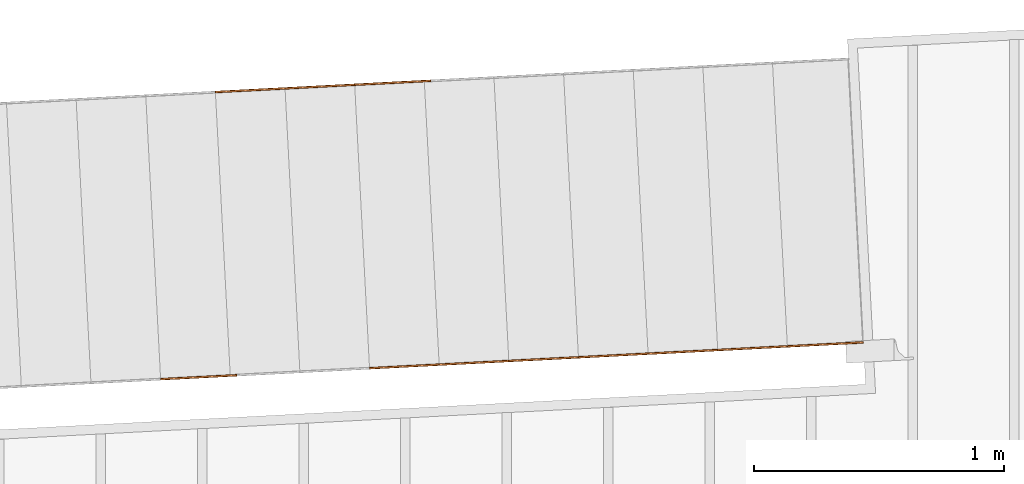
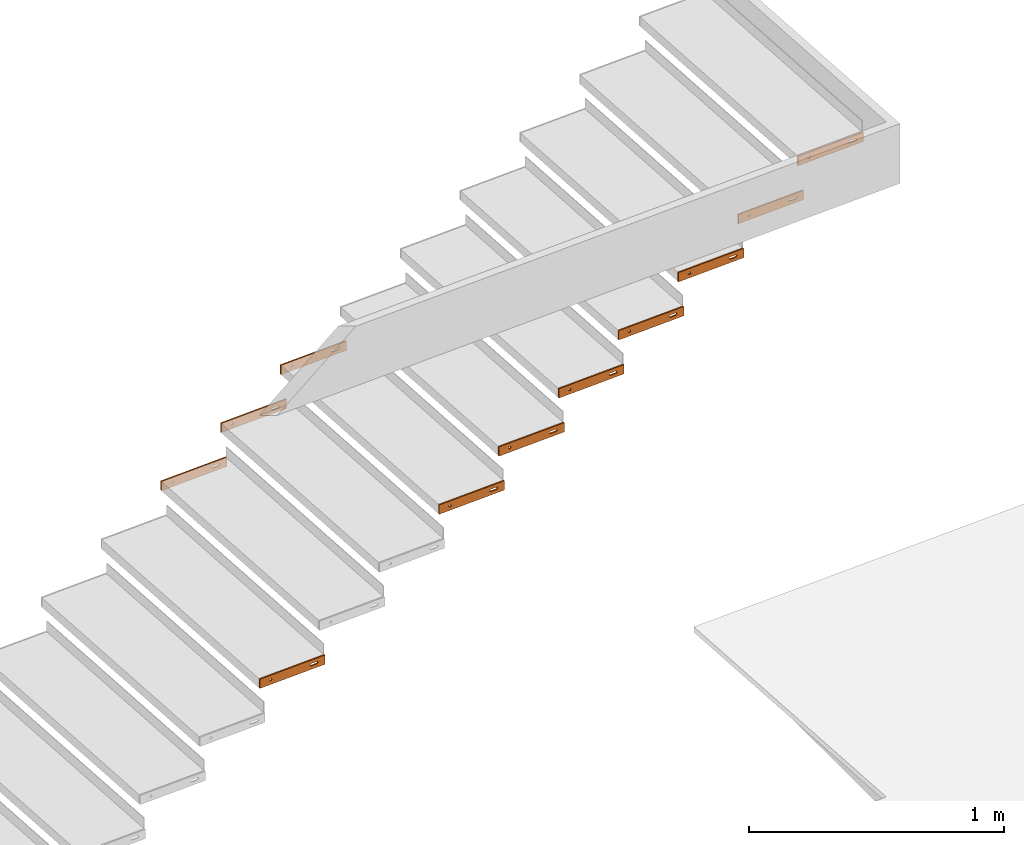
# One storey, part 18 of 23: 11 proxies.
"""IFC4 building model written with IfcOpenShell, lengths in feet."""

import ifcopenshell
import ifcopenshell.guid

model = None  # the IFC model being written
_history = None  # IfcOwnerHistory: only IFC2X3 demands one
_inside = {}  # id of a spatial element -> (the spatial element, [elements in it])
_under = {}  # id of a project, library or spatial element -> (it, [spatial elements below it])
_declared = {}  # id of a project -> (the project, [libraries it declares])
_typed = {}  # id of a type object -> (the type object, [elements of that type])
_made_of = {}  # id of a material, layer set ... -> (it, [elements and type objects made of it])


def new_model(schema):
    """Start an empty IFC model of exactly this schema.

    Asked for "IFC4X3", IfcOpenShell would pick the latest addendum, in which some entities
    have other attributes; the version numbers below select the first issue.
    IFC2X3 requires an IfcOwnerHistory on every rooted entity: one is made here for all.
    """
    global model, _history
    if schema == "IFC4X3":
        model = ifcopenshell.file(schema_version=(4, 3, 0, 0))
    else:
        model = ifcopenshell.file(schema=schema)
    _inside.clear()
    _under.clear()
    _declared.clear()
    _typed.clear()
    _made_of.clear()
    _history = None
    if model.schema == "IFC2X3":
        org = make("IfcOrganization", Name="unknown")
        user = make(
            "IfcPersonAndOrganization",
            ThePerson=make("IfcPerson", FamilyName="unknown"),
            TheOrganization=org,
        )
        app = make(
            "IfcApplication",
            ApplicationDeveloper=org,
            Version="unknown",
            ApplicationFullName="unknown",
            ApplicationIdentifier="unknown",
        )
        _history = make(
            "IfcOwnerHistory",
            OwningUser=user,
            OwningApplication=app,
            ChangeAction="ADDED",
            CreationDate=0,
        )
    return model


def make(cls, **values):
    """One entity of the class cls with the attributes given. An attribute that is None is left unset."""
    return model.create_entity(
        cls, **{name: value for name, value in values.items() if value is not None}
    )


def entity(cls, *values):
    """Any entity or typed value of the class cls, its attributes in the order of the schema. None: left unset."""
    e = model.create_entity(cls)
    for i, value in enumerate(values):
        if value is not None:
            e[i] = value
    return e


def rooted(cls, **values):
    """An entity with a GlobalId (a new one), such as an element, a storey or a relation."""
    return make(cls, GlobalId=ifcopenshell.guid.new(), OwnerHistory=_history, **values)


def si_unit(unit_type, name, prefix=None):
    """IfcSIUnit, for example si_unit("LENGTHUNIT", "METRE", prefix="MILLI")."""
    return make("IfcSIUnit", UnitType=unit_type, Prefix=prefix, Name=name)


def converted_unit(unit_type, name, factor, base, dimensions=None, offset=None):
    """IfcConversionBasedUnit, such as the inch: factor (a typed value) times the base unit."""
    return make(
        "IfcConversionBasedUnit"
        if offset is None
        else "IfcConversionBasedUnitWithOffset",
        ConversionOffset=offset,
        Dimensions=None
        if dimensions is None
        else entity("IfcDimensionalExponents", *dimensions),
        UnitType=unit_type,
        Name=name,
        ConversionFactor=make(
            "IfcMeasureWithUnit", ValueComponent=factor, UnitComponent=base
        ),
    )


def derived_unit(unit_type, elements):
    """IfcDerivedUnit: a product of units, each with its exponent."""
    return make(
        "IfcDerivedUnit",
        Elements=[
            make("IfcDerivedUnitElement", Unit=unit, Exponent=power)
            for unit, power in elements
        ],
        UnitType=unit_type,
    )


def assignment(units):
    """IfcUnitAssignment: the units of a project."""
    return None if units is None else make("IfcUnitAssignment", Units=units)


def point(xyz):
    """IfcCartesianPoint."""
    return None if xyz is None else make("IfcCartesianPoint", Coordinates=xyz)


def direction(xyz):
    """IfcDirection."""
    return None if xyz is None else make("IfcDirection", DirectionRatios=xyz)


def frame(location, z_axis=None, x_axis=None):
    """IfcAxis2Placement3D, a coordinate frame: its origin and axes. An axis left out is left unset."""
    return make(
        "IfcAxis2Placement3D",
        Location=point(location),
        Axis=direction(z_axis),
        RefDirection=direction(x_axis),
    )


def frame_2d(location, x_axis=None):
    """IfcAxis2Placement2D, a coordinate frame in the plane: its origin and x axis."""
    return make(
        "IfcAxis2Placement2D", Location=point(location), RefDirection=direction(x_axis)
    )


def origin():
    """The frame at (0, 0, 0) with its axes left unset."""
    return frame((0.0, 0.0, 0.0))


def place(relative_to, where):
    """IfcLocalPlacement: puts the frame where relative to a parent placement (None: the world)."""
    return make(
        "IfcLocalPlacement", PlacementRelTo=relative_to, RelativePlacement=where
    )


def context(
    kind, dimensions, precision=None, world=None, true_north=None, identifier=None
):
    """IfcGeometricRepresentationContext, for example the 3D "Model" context."""
    return make(
        "IfcGeometricRepresentationContext",
        ContextIdentifier=identifier,
        ContextType=kind,
        CoordinateSpaceDimension=dimensions,
        Precision=precision,
        WorldCoordinateSystem=world,
        TrueNorth=true_north,
    )


def subcontext(parent, identifier, kind, view, scale=None):
    """IfcGeometricRepresentationSubContext, for example "Body" below "Model"."""
    return make(
        "IfcGeometricRepresentationSubContext",
        ContextIdentifier=identifier,
        ContextType=kind,
        ParentContext=parent,
        TargetScale=scale,
        TargetView=view,
    )


def project(units=None, contexts=None):
    """IfcProject with its units and contexts."""
    return rooted(
        "IfcProject",
        Name="project",
        RepresentationContexts=contexts,
        UnitsInContext=assignment(units),
    )


def spatial(cls, under=None, at=None, **own):
    """A site, building, storey or space (cls), placed at a placement, below another one or the project."""
    s = rooted(cls, ObjectPlacement=at, **own)
    if under is not None:
        _under.setdefault(under.id(), (under, []))[1].append(s)
    return s


def polyline(points):
    """IfcPolyline through the points."""
    return make("IfcPolyline", Points=[point(p) for p in points])


def circle_curve(where, radius):
    """IfcCircle in the frame where."""
    return make("IfcCircle", Position=where, Radius=radius)


def parameter(value):
    """IfcParameterValue: where a trimmed curve begins or ends, as a parameter of its basis curve."""
    return model.create_entity("IfcParameterValue", value)


def trimmed(basis, trim1, trim2, sense, master):
    """IfcTrimmedCurve: the piece of a basis curve between two trims."""
    return make(
        "IfcTrimmedCurve",
        BasisCurve=basis,
        Trim1=trim1,
        Trim2=trim2,
        SenseAgreement=sense,
        MasterRepresentation=master,
    )


def segment(curve, same_sense, transition):
    """IfcCompositeCurveSegment."""
    return make(
        "IfcCompositeCurveSegment",
        Transition=transition,
        SameSense=same_sense,
        ParentCurve=curve,
    )


def composite_curve(segments, self_intersect=None):
    """IfcCompositeCurve: segments joined end to end."""
    return make("IfcCompositeCurve", Segments=segments, SelfIntersect=self_intersect)


def outline(outer, holes=None, kind="AREA"):
    """IfcArbitraryClosedProfileDef: a profile drawn as a closed curve; with holes, ...WithVoids."""
    if holes is None:
        return make("IfcArbitraryClosedProfileDef", ProfileType=kind, OuterCurve=outer)
    return make(
        "IfcArbitraryProfileDefWithVoids",
        ProfileType=kind,
        OuterCurve=outer,
        InnerCurves=holes,
    )


def extrude(swept, where, along, depth):
    """IfcExtrudedAreaSolid: the profile swept, set in the frame where, extruded along a direction by depth."""
    return make(
        "IfcExtrudedAreaSolid",
        SweptArea=swept,
        Position=where,
        ExtrudedDirection=direction(along),
        Depth=depth,
    )


def shape(context_of_items, identifier, shape_type, items):
    """IfcShapeRepresentation: the items that make up one representation, for example the "Body"."""
    return make(
        "IfcShapeRepresentation",
        ContextOfItems=context_of_items,
        RepresentationIdentifier=identifier,
        RepresentationType=shape_type,
        Items=items,
    )


def source(mapping_origin, context_of_items, identifier, shape_type, items):
    """IfcRepresentationMap: a shape defined once, which mapped items show again and again."""
    return make(
        "IfcRepresentationMap",
        MappingOrigin=mapping_origin,
        MappedRepresentation=shape(context_of_items, identifier, shape_type, items),
    )


def transform(
    local_origin,
    x_axis=None,
    y_axis=None,
    z_axis=None,
    scale=None,
    scale2=None,
    scale3=None,
    uniform=True,
):
    """IfcCartesianTransformationOperator3D, or its non-uniform kind. x_axis, y_axis, z_axis: its Axis1, 2, 3."""
    if uniform:
        return make(
            "IfcCartesianTransformationOperator3D",
            Axis1=direction(x_axis),
            Axis2=direction(y_axis),
            LocalOrigin=point(local_origin),
            Scale=scale,
            Axis3=direction(z_axis),
        )
    return make(
        "IfcCartesianTransformationOperator3DnonUniform",
        Axis1=direction(x_axis),
        Axis2=direction(y_axis),
        LocalOrigin=point(local_origin),
        Scale=scale,
        Axis3=direction(z_axis),
        Scale2=scale2,
        Scale3=scale3,
    )


def mapped(mapping_source, mapping_target):
    """IfcMappedItem: shows the shape of a source again, moved by a transform."""
    return make(
        "IfcMappedItem", MappingSource=mapping_source, MappingTarget=mapping_target
    )


def material(Name=None, Category=None):
    """IfcMaterial."""
    return make("IfcMaterial", Name=Name, Category=Category)


def made_of(thing, what):
    """Note that an element or type object is made of a material, layer set ...; save() writes the relation."""
    if what is not None:
        _made_of.setdefault(what.id(), (what, []))[1].append(thing)
    return thing


def type_object(cls, material=None, **own):
    """A type object (cls), such as IfcWallType, which elements share."""
    return made_of(rooted(cls, **own), material)


def type_shapes(of_type, sources):
    """Give a type object the sources (RepresentationMaps) that its elements show as mapped items."""
    of_type.RepresentationMaps = sources


def element(
    cls,
    number,
    at=None,
    inside=None,
    cuts=None,
    type_object=None,
    material=None,
    context=None,
    identifier="Body",
    shape_type=None,
    held_by="IfcProductDefinitionShape",
    body=None,
    shapes=None,
    **own,
):
    """One element of the class cls, such as IfcWall. Its Tag is "e" and its number.

    at: its placement. inside: the storey or other place that contains it. cuts: it is an
    opening in that element (IfcRelVoidsElement). A single representation is given by context,
    identifier, shape_type and body (its items); several are given by shapes. held_by: the class
    of the entity that holds the representations. save() writes the other relations.
    """
    e = rooted(cls, Tag="e%d" % number, ObjectPlacement=at, **own)
    if body is not None:
        shapes = [shape(context, identifier, shape_type, body)]
    if shapes is not None:
        e.Representation = make(held_by, Representations=shapes)
    if inside is not None:
        _inside.setdefault(inside.id(), (inside, []))[1].append(e)
    if cuts is not None:
        rooted(
            "IfcRelVoidsElement", RelatingBuildingElement=cuts, RelatedOpeningElement=e
        )
    if type_object is not None:
        _typed.setdefault(type_object.id(), (type_object, []))[1].append(e)
    return made_of(e, material)


def aggregate(whole, parts):
    """IfcRelAggregates: a whole, such as a stair, and the parts it consists of."""
    return rooted("IfcRelAggregates", RelatingObject=whole, RelatedObjects=parts)


def save(model, path):
    """Write the relations noted so far, then the file.

    IfcRelAggregates (storeys below a building ...), IfcRelContainedInSpatialStructure (elements
    in a storey), IfcRelDefinesByType, IfcRelAssociatesMaterial and IfcRelDeclares: one each for
    every whole, place, type object, material and project.
    """
    for whole, parts in _under.values():
        aggregate(whole, parts)
    for where, things in _inside.values():
        rooted(
            "IfcRelContainedInSpatialStructure",
            RelatedElements=things,
            RelatingStructure=where,
        )
    for kind, things in _typed.values():
        rooted("IfcRelDefinesByType", RelatedObjects=things, RelatingType=kind)
    for what, things in _made_of.values():
        rooted("IfcRelAssociatesMaterial", RelatedObjects=things, RelatingMaterial=what)
    for by, libraries in _declared.values():
        rooted("IfcRelDeclares", RelatingContext=by, RelatedDefinitions=libraries)
    model.write(path)


model = new_model("IFC4")

# Units and contexts
model_context_1 = context("Model", 3, precision=0.0001, world=origin(), true_north=direction((6.12303176911189e-17, 1.0)))
model_context_2 = context("Model", 3, precision=0.0001, world=origin(), true_north=direction((6.12303176911189e-17, 1.0)))
body_context = subcontext(model_context_2, "Body", "Model", "MODEL_VIEW")
ifc_project = project(units=[converted_unit("LENGTHUNIT", "FOOT", entity("IfcRatioMeasure", 0.3048), si_unit("LENGTHUNIT", "METRE"), dimensions=[1, 0, 0, 0, 0, 0, 0]), converted_unit("AREAUNIT", "SQUARE FOOT", entity("IfcRatioMeasure", 0.09290304), si_unit("AREAUNIT", "SQUARE_METRE"), dimensions=[2, 0, 0, 0, 0, 0, 0]), converted_unit("VOLUMEUNIT", "CUBIC FOOT", entity("IfcRatioMeasure", 0.028316846592), si_unit("VOLUMEUNIT", "CUBIC_METRE"), dimensions=[3, 0, 0, 0, 0, 0, 0]), converted_unit("PLANEANGLEUNIT", "DEGREE", entity("IfcRatioMeasure", 0.0174532925199433), si_unit("PLANEANGLEUNIT", "RADIAN"), dimensions=[0, 0, 0, 0, 0, 0, 0]), si_unit("MASSUNIT", "GRAM", prefix="KILO"), derived_unit("MASSDENSITYUNIT", [(si_unit("MASSUNIT", "GRAM", prefix="KILO"), 1), (si_unit("LENGTHUNIT", "METRE"), -3)]), derived_unit("MOMENTOFINERTIAUNIT", [(si_unit("LENGTHUNIT", "METRE"), 4)]), si_unit("TIMEUNIT", "SECOND"), si_unit("FREQUENCYUNIT", "HERTZ"), si_unit("THERMODYNAMICTEMPERATUREUNIT", "DEGREE_CELSIUS"), derived_unit("THERMALTRANSMITTANCEUNIT", [(si_unit("MASSUNIT", "GRAM", prefix="KILO"), 1), (si_unit("THERMODYNAMICTEMPERATUREUNIT", "KELVIN"), -1), (si_unit("TIMEUNIT", "SECOND"), -3)]), derived_unit("VOLUMETRICFLOWRATEUNIT", [(si_unit("LENGTHUNIT", "METRE"), 3), (si_unit("TIMEUNIT", "SECOND"), -1)]), si_unit("ELECTRICCURRENTUNIT", "AMPERE"), si_unit("ELECTRICVOLTAGEUNIT", "VOLT"), si_unit("POWERUNIT", "WATT"), si_unit("FORCEUNIT", "NEWTON"), si_unit("ILLUMINANCEUNIT", "LUX"), si_unit("LUMINOUSFLUXUNIT", "LUMEN"), si_unit("LUMINOUSINTENSITYUNIT", "CANDELA"), derived_unit("USERDEFINED", [(si_unit("MASSUNIT", "GRAM", prefix="KILO"), -1), (si_unit("LENGTHUNIT", "METRE"), -2), (si_unit("TIMEUNIT", "SECOND"), 3), (si_unit("LUMINOUSFLUXUNIT", "LUMEN"), 1)]), derived_unit("LINEARVELOCITYUNIT", [(si_unit("LENGTHUNIT", "METRE"), 1), (si_unit("TIMEUNIT", "SECOND"), -1)]), si_unit("PRESSUREUNIT", "PASCAL"), derived_unit("USERDEFINED", [(si_unit("LENGTHUNIT", "METRE"), -2), (si_unit("MASSUNIT", "GRAM", prefix="KILO"), 1), (si_unit("TIMEUNIT", "SECOND"), -2)]), derived_unit("LINEARFORCEUNIT", [(si_unit("MASSUNIT", "GRAM", prefix="KILO"), 1), (si_unit("LENGTHUNIT", "METRE"), 1), (si_unit("TIMEUNIT", "SECOND"), -2), (si_unit("LENGTHUNIT", "METRE"), -1)]), derived_unit("PLANARFORCEUNIT", [(si_unit("MASSUNIT", "GRAM", prefix="KILO"), 1), (si_unit("LENGTHUNIT", "METRE"), 1), (si_unit("TIMEUNIT", "SECOND"), -2), (si_unit("LENGTHUNIT", "METRE"), -2)])], contexts=[model_context_1])

# Site, building, storey
site_placement = place(None, origin())
site = spatial("IfcSite", under=ifc_project, at=site_placement, CompositionType="ELEMENT")
building_placement = place(site_placement, origin())
building = spatial("IfcBuilding", under=site, at=building_placement, CompositionType="ELEMENT")
storey_placement = place(building_placement, frame((0.0, 0.0, 10.8020833333333)))
storey = spatial("IfcBuildingStorey", under=building, at=storey_placement, Name="2ND FLOOR", CompositionType="ELEMENT", Elevation=10.8020833333333)

# Proxies
ifc_material = material(Name="GALV. STEEL TREAD", Category="Materials")
building_element_proxy_type_1 = type_object("IfcBuildingElementProxyType", Name="Generic Models 972:Generic Models 629", PredefinedType="NOTDEFINED", material=ifc_material)
shared_shape_1 = source(origin(), body_context, "Body", "SweptSolid", [
    extrude(outline(polyline([(-0.499999999999973, -0.0729166666666679), (0.499999999999967, -0.0729166666666679), (0.500000000000001, 0.0729166666666679), (-0.499999999999967, 0.0729166666666679), (-0.499999999999973, -0.0729166666666679)]), holes=[composite_curve([segment(trimmed(circle_curve(frame_2d((-0.333333333333324, 0.0), x_axis=(-1.0, 0.0)), 0.0182291666666717), [parameter(180.0)], [parameter(360.0)], True, "PARAMETER"), False, "CONTINUOUS"), segment(trimmed(circle_curve(frame_2d((-0.33333333333333, 0.0), x_axis=(-1.0, 0.0)), 0.0182291666666717), [parameter(360.0)], [parameter(180.0)], True, "PARAMETER"), False, "CONTINUOUS")], self_intersect=False), composite_curve([segment(polyline([(0.376206281053262, -0.018229166666675), (0.290460385613239, -0.0182291666667105)]), True, "CONTINUOUS"), segment(trimmed(circle_curve(frame_2d((0.290460385613239, 0.0), x_axis=(1.0, 0.0)), 0.0182291666666714), [parameter(89.999999999957)], [parameter(269.999999999957)], True, "PARAMETER"), False, "CONTINUOUS"), segment(polyline([(0.290460385613245, 0.0182291666666679), (0.376206281053234, 0.0182291666666679)]), True, "CONTINUOUS"), segment(trimmed(circle_curve(frame_2d((0.376206281053262, 0.0), x_axis=(-1.0, 0.0)), 0.0182291666666714), [parameter(90.0000000000894)], [parameter(270.000000000089)], True, "PARAMETER"), False, "CONTINUOUS")], self_intersect=False)]), frame((0.500405099798996, 0.0261679781215207, 0.0729166666666679), z_axis=(-0.0523359562429309, 0.998629534754575, 0.0), x_axis=(0.998629534754575, 0.0523359562429309, 0.0)), (0.0, 0.0, 1.0), 0.0208333333333866),
])
type_shapes(building_element_proxy_type_1, [shared_shape_1])
proxy_1_placement = place(storey_placement, frame((-229.797734568391, 969.063958932095, 6.41392543859647)))
element("IfcBuildingElementProxy", 1, at=proxy_1_placement, inside=storey, type_object=building_element_proxy_type_1, material=ifc_material, Name="Generic Models 972:Generic Models 629", ObjectType="Generic Models 972:Generic Models 629", PredefinedType="NOTDEFINED", context=body_context, shape_type="MappedRepresentation", body=[
    mapped(shared_shape_1, transform((0.0, 0.0, 0.0), scale=1.0)),
])
building_element_proxy_type_2 = type_object("IfcBuildingElementProxyType", Name="Generic Models 973:Generic Models 629", PredefinedType="NOTDEFINED", material=ifc_material)
shared_shape_2 = source(origin(), body_context, "Body", "SweptSolid", [
    extrude(outline(polyline([(-0.499999999999973, -0.0729166666666679), (0.499999999999967, -0.0729166666666679), (0.500000000000001, 0.0729166666666679), (-0.499999999999967, 0.0729166666666679), (-0.499999999999973, -0.0729166666666679)]), holes=[composite_curve([segment(trimmed(circle_curve(frame_2d((-0.33333333333333, 0.0), x_axis=(-1.0, 0.0)), 0.0182291666666717), [parameter(180.0)], [parameter(360.0)], True, "PARAMETER"), False, "CONTINUOUS"), segment(trimmed(circle_curve(frame_2d((-0.333333333333336, 0.0), x_axis=(-1.0, 0.0)), 0.0182291666666717), [parameter(360.0)], [parameter(180.0)], True, "PARAMETER"), False, "CONTINUOUS")], self_intersect=False), composite_curve([segment(polyline([(0.376206281053256, -0.018229166666675), (0.290460385613233, -0.0182291666667105)]), True, "CONTINUOUS"), segment(trimmed(circle_curve(frame_2d((0.290460385613233, 0.0), x_axis=(1.0, 0.0)), 0.0182291666666714), [parameter(89.999999999957)], [parameter(269.999999999957)], True, "PARAMETER"), False, "CONTINUOUS"), segment(polyline([(0.290460385613239, 0.0182291666666679), (0.376206281053228, 0.0182291666666679)]), True, "CONTINUOUS"), segment(trimmed(circle_curve(frame_2d((0.376206281053256, 0.0), x_axis=(-1.0, 0.0)), 0.0182291666666714), [parameter(90.0000000000894)], [parameter(270.000000000089)], True, "PARAMETER"), False, "CONTINUOUS")], self_intersect=False)]), frame((0.500405099798996, 0.0261679781215207, 0.0729166666666679), z_axis=(-0.0523359562429309, 0.998629534754575, 0.0), x_axis=(0.998629534754575, 0.0523359562429309, 0.0)), (0.0, 0.0, 1.0), 0.0208333333333866),
])
type_shapes(building_element_proxy_type_2, [shared_shape_2])
proxy_2_placement = place(storey_placement, frame((-230.712606310766, 969.016012535749, 5.85252192982451)))
element("IfcBuildingElementProxy", 2, at=proxy_2_placement, inside=storey, type_object=building_element_proxy_type_2, material=ifc_material, Name="Generic Models 973:Generic Models 629", ObjectType="Generic Models 973:Generic Models 629", PredefinedType="NOTDEFINED", context=body_context, shape_type="MappedRepresentation", body=[
    mapped(shared_shape_2, transform((0.0, 0.0, 0.0), scale=1.0)),
])
building_element_proxy_type_3 = type_object("IfcBuildingElementProxyType", Name="Generic Models 974:Generic Models 629", PredefinedType="NOTDEFINED", material=ifc_material)
shared_shape_3 = source(origin(), body_context, "Body", "SweptSolid", [
    extrude(outline(polyline([(-0.499999999999973, -0.0729166666666679), (0.499999999999967, -0.0729166666666679), (0.500000000000001, 0.0729166666666679), (-0.499999999999967, 0.0729166666666679), (-0.499999999999973, -0.0729166666666679)]), holes=[composite_curve([segment(trimmed(circle_curve(frame_2d((-0.33333333333333, 0.0), x_axis=(-1.0, 0.0)), 0.0182291666666717), [parameter(180.0)], [parameter(360.0)], True, "PARAMETER"), False, "CONTINUOUS"), segment(trimmed(circle_curve(frame_2d((-0.333333333333336, 0.0), x_axis=(-1.0, 0.0)), 0.0182291666666717), [parameter(360.0)], [parameter(180.0)], True, "PARAMETER"), False, "CONTINUOUS")], self_intersect=False), composite_curve([segment(polyline([(0.376206281053256, -0.018229166666675), (0.290460385613233, -0.0182291666667105)]), True, "CONTINUOUS"), segment(trimmed(circle_curve(frame_2d((0.290460385613233, 0.0), x_axis=(1.0, 0.0)), 0.0182291666666714), [parameter(89.999999999957)], [parameter(269.999999999957)], True, "PARAMETER"), False, "CONTINUOUS"), segment(polyline([(0.290460385613239, 0.0182291666666679), (0.376206281053228, 0.0182291666666679)]), True, "CONTINUOUS"), segment(trimmed(circle_curve(frame_2d((0.376206281053256, 0.0), x_axis=(-1.0, 0.0)), 0.0182291666666714), [parameter(90.0000000000894)], [parameter(270.000000000089)], True, "PARAMETER"), False, "CONTINUOUS")], self_intersect=False)]), frame((0.500405099798996, 0.0261679781216344, 0.0729166666666679), z_axis=(-0.0523359562429309, 0.998629534754575, 0.0), x_axis=(0.998629534754575, 0.0523359562429309, 0.0)), (0.0, 0.0, 1.0), 0.0208333333333866),
])
type_shapes(building_element_proxy_type_3, [shared_shape_3])
proxy_3_placement = place(storey_placement, frame((-231.627478053141, 968.968066139402, 5.29111842105256)))
element("IfcBuildingElementProxy", 3, at=proxy_3_placement, inside=storey, type_object=building_element_proxy_type_3, material=ifc_material, Name="Generic Models 974:Generic Models 629", ObjectType="Generic Models 974:Generic Models 629", PredefinedType="NOTDEFINED", context=body_context, shape_type="MappedRepresentation", body=[
    mapped(shared_shape_3, transform((0.0, 0.0, 0.0), scale=1.0)),
])
building_element_proxy_type_4 = type_object("IfcBuildingElementProxyType", Name="Generic Models 890:Generic Models 629", PredefinedType="NOTDEFINED", material=ifc_material)
shared_shape_4 = source(origin(), body_context, "Body", "SweptSolid", [
    extrude(outline(polyline([(-0.499999999999979, -0.0729166666666679), (0.499999999999961, -0.0729166666666679), (0.499999999999973, 0.0729166666666679), (-0.499999999999967, 0.0729166666666679), (-0.499999999999979, -0.0729166666666679)]), holes=[composite_curve([segment(trimmed(circle_curve(frame_2d((-0.333333333333308, 0.0), x_axis=(-1.0, 0.0)), 0.0182291666666717), [parameter(180.0)], [parameter(360.0)], True, "PARAMETER"), False, "CONTINUOUS"), segment(trimmed(circle_curve(frame_2d((-0.333333333333308, 0.0), x_axis=(-1.0, 0.0)), 0.0182291666666717), [parameter(360.0)], [parameter(180.0)], True, "PARAMETER"), False, "CONTINUOUS")], self_intersect=False), composite_curve([segment(polyline([(0.37620628105325, -0.018229166666675), (0.29046038561329, -0.0182291666667105)]), True, "CONTINUOUS"), segment(trimmed(circle_curve(frame_2d((0.29046038561329, 0.0), x_axis=(1.0, 0.0)), 0.0182291666666714), [parameter(89.999999999957)], [parameter(269.999999999957)], True, "PARAMETER"), False, "CONTINUOUS"), segment(polyline([(0.29046038561329, 0.0182291666666679), (0.376206281053256, 0.0182291666666679)]), True, "CONTINUOUS"), segment(trimmed(circle_curve(frame_2d((0.376206281053256, 0.0), x_axis=(-1.0, 0.0)), 0.0182291666666714), [parameter(90.0000000000002)], [parameter(270.0)], True, "PARAMETER"), False, "CONTINUOUS")], self_intersect=False)]), frame((0.500405099799025, 0.0261679781216344, 0.0729166666666679), z_axis=(-0.0523359562429309, 0.998629534754575, 0.0), x_axis=(0.998629534754575, 0.0523359562429309, 0.0)), (0.0, 0.0, 1.0), 0.0208333333333866),
])
type_shapes(building_element_proxy_type_4, [shared_shape_4])
proxy_4_placement = place(storey_placement, frame((-229.602565064899, 965.339902958694, 6.41392543859251)))
element("IfcBuildingElementProxy", 4, at=proxy_4_placement, inside=storey, type_object=building_element_proxy_type_4, material=ifc_material, Name="Generic Models 890:Generic Models 629", ObjectType="Generic Models 890:Generic Models 629", PredefinedType="NOTDEFINED", context=body_context, shape_type="MappedRepresentation", body=[
    mapped(shared_shape_4, transform((0.0, 0.0, 0.0), scale=1.0)),
])
building_element_proxy_type_5 = type_object("IfcBuildingElementProxyType", Name="Generic Models 892:Generic Models 629", PredefinedType="NOTDEFINED", material=ifc_material)
shared_shape_5 = source(origin(), body_context, "Body", "SweptSolid", [
    extrude(outline(polyline([(-0.499999999999973, -0.0729166666666679), (0.499999999999967, -0.0729166666666679), (0.499999999999979, 0.0729166666666679), (-0.499999999999961, 0.0729166666666679), (-0.499999999999973, -0.0729166666666679)]), holes=[composite_curve([segment(trimmed(circle_curve(frame_2d((-0.333333333333302, 0.0), x_axis=(-1.0, 0.0)), 0.0182291666666717), [parameter(180.0)], [parameter(360.0)], True, "PARAMETER"), False, "CONTINUOUS"), segment(trimmed(circle_curve(frame_2d((-0.333333333333302, 0.0), x_axis=(-1.0, 0.0)), 0.0182291666666717), [parameter(360.0)], [parameter(180.0)], True, "PARAMETER"), False, "CONTINUOUS")], self_intersect=False), composite_curve([segment(polyline([(0.376206281053256, -0.018229166666675), (0.290460385613296, -0.0182291666667105)]), True, "CONTINUOUS"), segment(trimmed(circle_curve(frame_2d((0.290460385613296, 0.0), x_axis=(1.0, 0.0)), 0.0182291666666714), [parameter(89.999999999957)], [parameter(269.999999999957)], True, "PARAMETER"), False, "CONTINUOUS"), segment(polyline([(0.290460385613296, 0.0182291666666679), (0.376206281053262, 0.0182291666666679)]), True, "CONTINUOUS"), segment(trimmed(circle_curve(frame_2d((0.376206281053262, 0.0), x_axis=(-1.0, 0.0)), 0.0182291666666714), [parameter(90.0000000000002)], [parameter(270.0)], True, "PARAMETER"), False, "CONTINUOUS")], self_intersect=False)]), frame((0.500405099799025, 0.0261679781215207, 0.0729166666666679), z_axis=(-0.0523359562429309, 0.998629534754575, 0.0), x_axis=(0.998629534754575, 0.0523359562429309, 0.0)), (0.0, 0.0, 1.0), 0.0208333333333866),
])
type_shapes(building_element_proxy_type_5, [shared_shape_5])
proxy_5_placement = place(storey_placement, frame((-224.113334610648, 965.627581336774, 9.78234649122425)))
element("IfcBuildingElementProxy", 5, at=proxy_5_placement, inside=storey, type_object=building_element_proxy_type_5, material=ifc_material, Name="Generic Models 892:Generic Models 629", ObjectType="Generic Models 892:Generic Models 629", PredefinedType="NOTDEFINED", context=body_context, shape_type="MappedRepresentation", body=[
    mapped(shared_shape_5, transform((0.0, 0.0, 0.0), scale=1.0)),
])
building_element_proxy_type_6 = type_object("IfcBuildingElementProxyType", Name="Generic Models 894:Generic Models 629", PredefinedType="NOTDEFINED", material=ifc_material)
shared_shape_6 = source(origin(), body_context, "Body", "SweptSolid", [
    extrude(outline(polyline([(-0.499999999999973, -0.0729166666666679), (0.499999999999967, -0.0729166666666679), (0.499999999999979, 0.0729166666666679), (-0.499999999999961, 0.0729166666666679), (-0.499999999999973, -0.0729166666666679)]), holes=[composite_curve([segment(trimmed(circle_curve(frame_2d((-0.333333333333302, 0.0), x_axis=(-1.0, 0.0)), 0.0182291666666717), [parameter(180.0)], [parameter(360.0)], True, "PARAMETER"), False, "CONTINUOUS"), segment(trimmed(circle_curve(frame_2d((-0.333333333333302, 0.0), x_axis=(-1.0, 0.0)), 0.0182291666666717), [parameter(360.0)], [parameter(180.0)], True, "PARAMETER"), False, "CONTINUOUS")], self_intersect=False), composite_curve([segment(polyline([(0.376206281053256, -0.018229166666675), (0.290460385613296, -0.0182291666667105)]), True, "CONTINUOUS"), segment(trimmed(circle_curve(frame_2d((0.290460385613296, 0.0), x_axis=(1.0, 0.0)), 0.0182291666666714), [parameter(89.999999999957)], [parameter(269.999999999957)], True, "PARAMETER"), False, "CONTINUOUS"), segment(polyline([(0.290460385613296, 0.0182291666666679), (0.376206281053262, 0.0182291666666679)]), True, "CONTINUOUS"), segment(trimmed(circle_curve(frame_2d((0.376206281053262, 0.0), x_axis=(-1.0, 0.0)), 0.0182291666666714), [parameter(90.0000000000002)], [parameter(270.0)], True, "PARAMETER"), False, "CONTINUOUS")], self_intersect=False)]), frame((0.500405099799025, 0.0261679781215207, 0.0729166666666679), z_axis=(-0.0523359562429309, 0.998629534754575, 0.0), x_axis=(0.998629534754575, 0.0523359562429309, 0.0)), (0.0, 0.0, 1.0), 0.0208333333333866),
])
type_shapes(building_element_proxy_type_6, [shared_shape_6])
proxy_6_placement = place(storey_placement, frame((-225.028206353023, 965.579634940428, 9.2209429824523)))
element("IfcBuildingElementProxy", 6, at=proxy_6_placement, inside=storey, type_object=building_element_proxy_type_6, material=ifc_material, Name="Generic Models 894:Generic Models 629", ObjectType="Generic Models 894:Generic Models 629", PredefinedType="NOTDEFINED", context=body_context, shape_type="MappedRepresentation", body=[
    mapped(shared_shape_6, transform((0.0, 0.0, 0.0), scale=1.0)),
])
building_element_proxy_type_7 = type_object("IfcBuildingElementProxyType", Name="Generic Models 896:Generic Models 629", PredefinedType="NOTDEFINED", material=ifc_material)
shared_shape_7 = source(origin(), body_context, "Body", "SweptSolid", [
    extrude(outline(polyline([(-0.499999999999979, -0.0729166666666679), (0.499999999999961, -0.0729166666666679), (0.499999999999973, 0.0729166666666679), (-0.499999999999967, 0.0729166666666679), (-0.499999999999979, -0.0729166666666679)]), holes=[composite_curve([segment(trimmed(circle_curve(frame_2d((-0.333333333333308, 0.0), x_axis=(-1.0, 0.0)), 0.0182291666666717), [parameter(180.0)], [parameter(360.0)], True, "PARAMETER"), False, "CONTINUOUS"), segment(trimmed(circle_curve(frame_2d((-0.333333333333308, 0.0), x_axis=(-1.0, 0.0)), 0.0182291666666717), [parameter(360.0)], [parameter(180.0)], True, "PARAMETER"), False, "CONTINUOUS")], self_intersect=False), composite_curve([segment(polyline([(0.37620628105325, -0.018229166666675), (0.29046038561329, -0.0182291666667105)]), True, "CONTINUOUS"), segment(trimmed(circle_curve(frame_2d((0.29046038561329, 0.0), x_axis=(1.0, 0.0)), 0.0182291666666714), [parameter(89.999999999957)], [parameter(269.999999999957)], True, "PARAMETER"), False, "CONTINUOUS"), segment(polyline([(0.29046038561329, 0.0182291666666679), (0.376206281053256, 0.0182291666666679)]), True, "CONTINUOUS"), segment(trimmed(circle_curve(frame_2d((0.376206281053256, 0.0), x_axis=(-1.0, 0.0)), 0.0182291666666714), [parameter(90.0000000000002)], [parameter(270.0)], True, "PARAMETER"), False, "CONTINUOUS")], self_intersect=False)]), frame((0.500405099799025, 0.0261679781216344, 0.0729166666666679), z_axis=(-0.0523359562429309, 0.998629534754575, 0.0), x_axis=(0.998629534754575, 0.0523359562429309, 0.0)), (0.0, 0.0, 1.0), 0.0208333333333866),
])
type_shapes(building_element_proxy_type_7, [shared_shape_7])
proxy_7_placement = place(storey_placement, frame((-225.943078095398, 965.531688544081, 8.65953947368034)))
element("IfcBuildingElementProxy", 7, at=proxy_7_placement, inside=storey, type_object=building_element_proxy_type_7, material=ifc_material, Name="Generic Models 896:Generic Models 629", ObjectType="Generic Models 896:Generic Models 629", PredefinedType="NOTDEFINED", context=body_context, shape_type="MappedRepresentation", body=[
    mapped(shared_shape_7, transform((0.0, 0.0, 0.0), scale=1.0)),
])
building_element_proxy_type_8 = type_object("IfcBuildingElementProxyType", Name="Generic Models 898:Generic Models 629", PredefinedType="NOTDEFINED", material=ifc_material)
shared_shape_8 = source(origin(), body_context, "Body", "SweptSolid", [
    extrude(outline(polyline([(-0.499999999999973, -0.0729166666666679), (0.499999999999967, -0.0729166666666679), (0.499999999999979, 0.0729166666666679), (-0.499999999999961, 0.0729166666666679), (-0.499999999999973, -0.0729166666666679)]), holes=[composite_curve([segment(trimmed(circle_curve(frame_2d((-0.333333333333302, 0.0), x_axis=(-1.0, 0.0)), 0.0182291666666717), [parameter(180.0)], [parameter(360.0)], True, "PARAMETER"), False, "CONTINUOUS"), segment(trimmed(circle_curve(frame_2d((-0.333333333333302, 0.0), x_axis=(-1.0, 0.0)), 0.0182291666666717), [parameter(360.0)], [parameter(180.0)], True, "PARAMETER"), False, "CONTINUOUS")], self_intersect=False), composite_curve([segment(polyline([(0.376206281053256, -0.018229166666675), (0.290460385613296, -0.0182291666667105)]), True, "CONTINUOUS"), segment(trimmed(circle_curve(frame_2d((0.290460385613296, 0.0), x_axis=(1.0, 0.0)), 0.0182291666666714), [parameter(89.999999999957)], [parameter(269.999999999957)], True, "PARAMETER"), False, "CONTINUOUS"), segment(polyline([(0.290460385613296, 0.0182291666666679), (0.376206281053262, 0.0182291666666679)]), True, "CONTINUOUS"), segment(trimmed(circle_curve(frame_2d((0.376206281053262, 0.0), x_axis=(-1.0, 0.0)), 0.0182291666666714), [parameter(90.0000000000002)], [parameter(270.0)], True, "PARAMETER"), False, "CONTINUOUS")], self_intersect=False)]), frame((0.500405099799025, 0.0261679781215207, 0.0729166666666679), z_axis=(-0.0523359562429309, 0.998629534754575, 0.0), x_axis=(0.998629534754575, 0.0523359562429309, 0.0)), (0.0, 0.0, 1.0), 0.0208333333333866),
])
type_shapes(building_element_proxy_type_8, [shared_shape_8])
proxy_8_placement = place(storey_placement, frame((-226.857949837773, 965.483742147734, 8.09813596490839)))
element("IfcBuildingElementProxy", 8, at=proxy_8_placement, inside=storey, type_object=building_element_proxy_type_8, material=ifc_material, Name="Generic Models 898:Generic Models 629", ObjectType="Generic Models 898:Generic Models 629", PredefinedType="NOTDEFINED", context=body_context, shape_type="MappedRepresentation", body=[
    mapped(shared_shape_8, transform((0.0, 0.0, 0.0), scale=1.0)),
])
building_element_proxy_type_9 = type_object("IfcBuildingElementProxyType", Name="Generic Models 900:Generic Models 629", PredefinedType="NOTDEFINED", material=ifc_material)
shared_shape_9 = source(origin(), body_context, "Body", "SweptSolid", [
    extrude(outline(polyline([(-0.499999999999973, -0.0729166666666679), (0.499999999999967, -0.0729166666666679), (0.499999999999979, 0.0729166666666679), (-0.499999999999961, 0.0729166666666679), (-0.499999999999973, -0.0729166666666679)]), holes=[composite_curve([segment(trimmed(circle_curve(frame_2d((-0.333333333333302, 0.0), x_axis=(-1.0, 0.0)), 0.0182291666666717), [parameter(180.0)], [parameter(360.0)], True, "PARAMETER"), False, "CONTINUOUS"), segment(trimmed(circle_curve(frame_2d((-0.333333333333302, 0.0), x_axis=(-1.0, 0.0)), 0.0182291666666717), [parameter(360.0)], [parameter(180.0)], True, "PARAMETER"), False, "CONTINUOUS")], self_intersect=False), composite_curve([segment(polyline([(0.376206281053256, -0.018229166666675), (0.290460385613296, -0.0182291666667105)]), True, "CONTINUOUS"), segment(trimmed(circle_curve(frame_2d((0.290460385613296, 0.0), x_axis=(1.0, 0.0)), 0.0182291666666714), [parameter(89.999999999957)], [parameter(269.999999999957)], True, "PARAMETER"), False, "CONTINUOUS"), segment(polyline([(0.290460385613296, 0.0182291666666679), (0.376206281053262, 0.0182291666666679)]), True, "CONTINUOUS"), segment(trimmed(circle_curve(frame_2d((0.376206281053262, 0.0), x_axis=(-1.0, 0.0)), 0.0182291666666714), [parameter(90.0000000000002)], [parameter(270.0)], True, "PARAMETER"), False, "CONTINUOUS")], self_intersect=False)]), frame((0.500405099799025, 0.0261679781215207, 0.0729166666666679), z_axis=(-0.0523359562429309, 0.998629534754575, 0.0), x_axis=(0.998629534754575, 0.0523359562429309, 0.0)), (0.0, 0.0, 1.0), 0.0208333333333866),
])
type_shapes(building_element_proxy_type_9, [shared_shape_9])
proxy_9_placement = place(storey_placement, frame((-227.772821580149, 965.435795751388, 7.53673245613643)))
element("IfcBuildingElementProxy", 9, at=proxy_9_placement, inside=storey, type_object=building_element_proxy_type_9, material=ifc_material, Name="Generic Models 900:Generic Models 629", ObjectType="Generic Models 900:Generic Models 629", PredefinedType="NOTDEFINED", context=body_context, shape_type="MappedRepresentation", body=[
    mapped(shared_shape_9, transform((0.0, 0.0, 0.0), scale=1.0)),
])
building_element_proxy_type_10 = type_object("IfcBuildingElementProxyType", Name="Generic Models 902:Generic Models 629", PredefinedType="NOTDEFINED", material=ifc_material)
shared_shape_10 = source(origin(), body_context, "Body", "SweptSolid", [
    extrude(outline(polyline([(-0.499999999999973, -0.0729166666666679), (0.499999999999967, -0.0729166666666679), (0.499999999999979, 0.0729166666666679), (-0.499999999999961, 0.0729166666666679), (-0.499999999999973, -0.0729166666666679)]), holes=[composite_curve([segment(trimmed(circle_curve(frame_2d((-0.333333333333302, 0.0), x_axis=(-1.0, 0.0)), 0.0182291666666717), [parameter(180.0)], [parameter(360.0)], True, "PARAMETER"), False, "CONTINUOUS"), segment(trimmed(circle_curve(frame_2d((-0.333333333333302, 0.0), x_axis=(-1.0, 0.0)), 0.0182291666666717), [parameter(360.0)], [parameter(180.0)], True, "PARAMETER"), False, "CONTINUOUS")], self_intersect=False), composite_curve([segment(polyline([(0.376206281053256, -0.018229166666675), (0.290460385613296, -0.0182291666667105)]), True, "CONTINUOUS"), segment(trimmed(circle_curve(frame_2d((0.290460385613296, 0.0), x_axis=(1.0, 0.0)), 0.0182291666666714), [parameter(89.999999999957)], [parameter(269.999999999957)], True, "PARAMETER"), False, "CONTINUOUS"), segment(polyline([(0.290460385613296, 0.0182291666666679), (0.376206281053262, 0.0182291666666679)]), True, "CONTINUOUS"), segment(trimmed(circle_curve(frame_2d((0.376206281053262, 0.0), x_axis=(-1.0, 0.0)), 0.0182291666666714), [parameter(90.0000000000002)], [parameter(270.0)], True, "PARAMETER"), False, "CONTINUOUS")], self_intersect=False)]), frame((0.500405099799025, 0.0261679781215207, 0.0729166666666679), z_axis=(-0.0523359562429309, 0.998629534754575, 0.0), x_axis=(0.998629534754575, 0.0523359562429309, 0.0)), (0.0, 0.0, 1.0), 0.0208333333333866),
])
type_shapes(building_element_proxy_type_10, [shared_shape_10])
proxy_10_placement = place(storey_placement, frame((-228.687693322524, 965.387849355041, 6.97532894736447)))
element("IfcBuildingElementProxy", 10, at=proxy_10_placement, inside=storey, type_object=building_element_proxy_type_10, material=ifc_material, Name="Generic Models 902:Generic Models 629", ObjectType="Generic Models 902:Generic Models 629", PredefinedType="NOTDEFINED", context=body_context, shape_type="MappedRepresentation", body=[
    mapped(shared_shape_10, transform((0.0, 0.0, 0.0), scale=1.0)),
])
building_element_proxy_type_11 = type_object("IfcBuildingElementProxyType", Name="Generic Models 908:Generic Models 629", PredefinedType="NOTDEFINED", material=ifc_material)
shared_shape_11 = source(origin(), body_context, "Body", "SweptSolid", [
    extrude(outline(polyline([(-0.499999999999973, -0.0729166666666679), (0.499999999999967, -0.0729166666666679), (0.499999999999979, 0.0729166666666679), (-0.499999999999961, 0.0729166666666679), (-0.499999999999973, -0.0729166666666679)]), holes=[composite_curve([segment(trimmed(circle_curve(frame_2d((-0.333333333333302, 0.0), x_axis=(-1.0, 0.0)), 0.0182291666666717), [parameter(180.0)], [parameter(360.0)], True, "PARAMETER"), False, "CONTINUOUS"), segment(trimmed(circle_curve(frame_2d((-0.333333333333302, 0.0), x_axis=(-1.0, 0.0)), 0.0182291666666717), [parameter(360.0)], [parameter(180.0)], True, "PARAMETER"), False, "CONTINUOUS")], self_intersect=False), composite_curve([segment(polyline([(0.376206281053256, -0.0182291666666732), (0.290460385613296, -0.0182291666667105)]), True, "CONTINUOUS"), segment(trimmed(circle_curve(frame_2d((0.290460385613296, 0.0), x_axis=(1.0, 0.0)), 0.0182291666666714), [parameter(89.999999999957)], [parameter(269.999999999957)], True, "PARAMETER"), False, "CONTINUOUS"), segment(polyline([(0.290460385613296, 0.0182291666666696), (0.376206281053262, 0.0182291666666679)]), True, "CONTINUOUS"), segment(trimmed(circle_curve(frame_2d((0.376206281053262, 0.0), x_axis=(-1.0, 0.0)), 0.0182291666666714), [parameter(90.0000000000002)], [parameter(270.0)], True, "PARAMETER"), False, "CONTINUOUS")], self_intersect=False)]), frame((0.500405099799025, 0.0261679781215207, 0.0729166666666679), z_axis=(-0.0523359562429309, 0.998629534754575, 0.0), x_axis=(0.998629534754575, 0.0523359562429309, 0.0)), (0.0, 0.0, 1.0), 0.0208333333333866),
])
type_shapes(building_element_proxy_type_11, [shared_shape_11])
proxy_11_placement = place(storey_placement, frame((-232.347180292025, 965.196063769654, 4.72971491227665)))
element("IfcBuildingElementProxy", 11, at=proxy_11_placement, inside=storey, type_object=building_element_proxy_type_11, material=ifc_material, Name="Generic Models 908:Generic Models 629", ObjectType="Generic Models 908:Generic Models 629", PredefinedType="NOTDEFINED", context=body_context, shape_type="MappedRepresentation", body=[
    mapped(shared_shape_11, transform((0.0, 0.0, 0.0), scale=1.0)),
])

save(model, "model.ifc")
